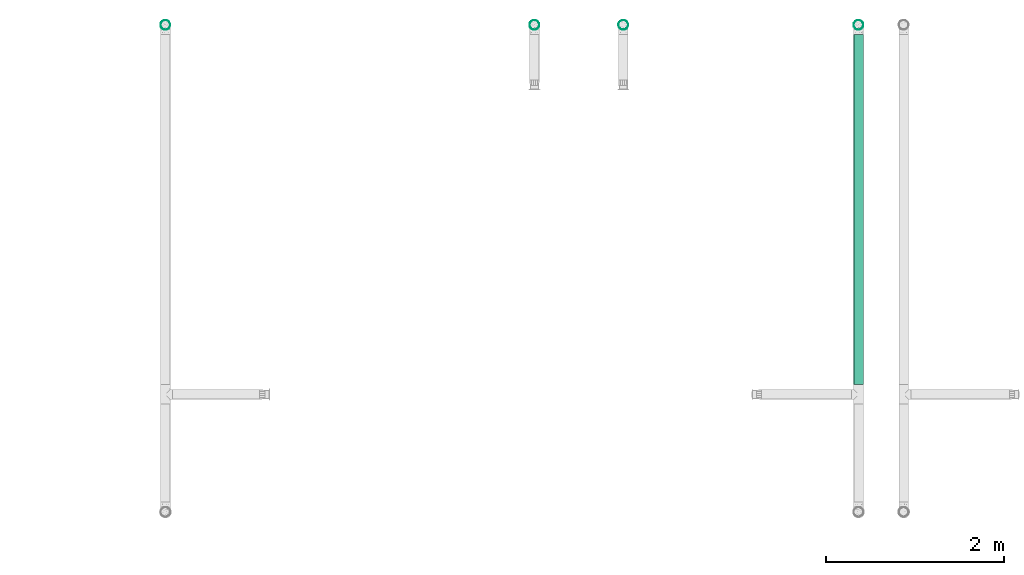
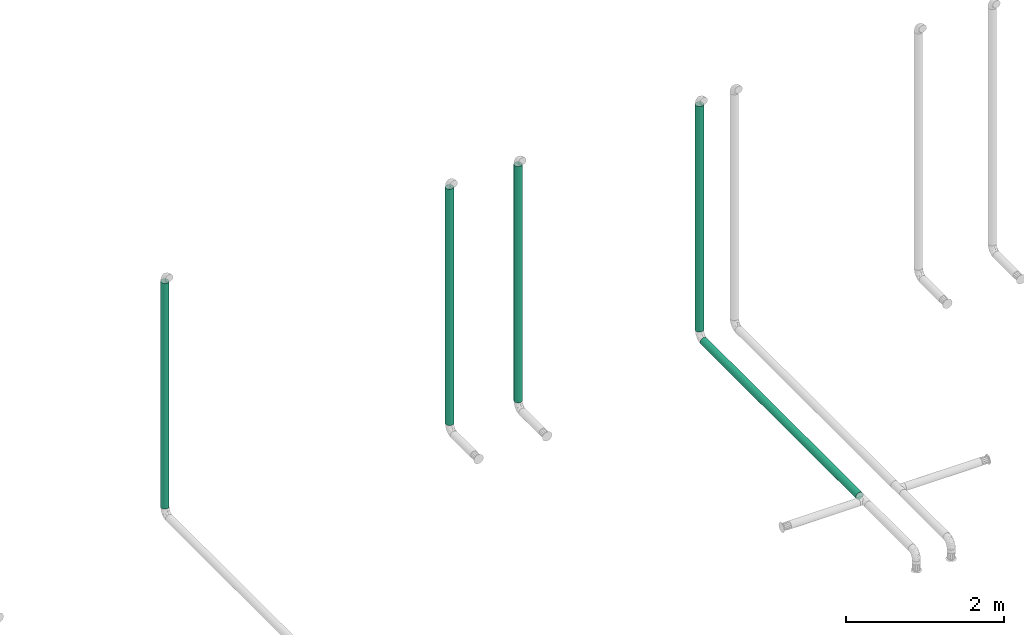
# One storey, part 9 of 115: 5 flow segments.
"""IFC2X3 building model written with IfcOpenShell, lengths in millimetres."""

from ifc_helpers import new_model, entity, si_unit, converted_unit, derived_unit, direction, frame, origin_with_axes, origin_2d_with_axis, place, context, subcontext, project, spatial, hollow_circle, extrude, source, transform, mapped, material, layer, layer_set, layer_usage, type_object, element, save


model = new_model("IFC2X3")

# Units and contexts
model_context = context("Model", 3, precision=1e-05, world=origin_with_axes(), true_north=direction((0.0, 1.0)))
body_context = subcontext(model_context, "Body", "Model", "MODEL_VIEW")
ifc_project = project(units=[si_unit("AREAUNIT", "SQUARE_METRE"), si_unit("VOLUMEUNIT", "CUBIC_METRE", prefix="DECI"), si_unit("TIMEUNIT", "SECOND"), si_unit("THERMODYNAMICTEMPERATUREUNIT", "DEGREE_CELSIUS"), si_unit("PRESSUREUNIT", "PASCAL"), si_unit("MASSUNIT", "GRAM", prefix="KILO"), si_unit("LENGTHUNIT", "METRE", prefix="MILLI"), si_unit("POWERUNIT", "WATT"), si_unit("ELECTRICCURRENTUNIT", "AMPERE"), si_unit("ELECTRICVOLTAGEUNIT", "VOLT"), derived_unit("VOLUMETRICFLOWRATEUNIT", [(si_unit("VOLUMEUNIT", "CUBIC_METRE", prefix="DECI"), 1), (si_unit("TIMEUNIT", "SECOND"), -1)]), derived_unit("LINEARVELOCITYUNIT", [(si_unit("LENGTHUNIT", "METRE"), 1), (si_unit("TIMEUNIT", "SECOND"), -1)]), derived_unit("MASSDENSITYUNIT", [(si_unit("MASSUNIT", "GRAM", prefix="KILO"), 1), (si_unit("VOLUMEUNIT", "CUBIC_METRE"), -1)]), converted_unit("PLANEANGLEUNIT", "DEGREE", entity("IfcRatioMeasure", 0.01745), si_unit("PLANEANGLEUNIT", "RADIAN"), dimensions=[0, 0, 0, 0, 0, 0, 0])], contexts=[model_context])

# Site, building, storey
site_placement = place(None, origin_with_axes())
site = spatial("IfcSite", under=ifc_project, at=site_placement, CompositionType="ELEMENT")
building_placement = place(site_placement, origin_with_axes())
building = spatial("IfcBuilding", under=site, at=building_placement, Name="mc-building", CompositionType="ELEMENT")
storey_placement = place(building_placement, frame((0.0, 0.0, 2950.0), z_axis=(0.0, 0.0, 1.0), x_axis=(1.0, 0.0, 0.0)))
storey = spatial("IfcBuildingStorey", under=building, at=storey_placement, Name="2. Korrus", CompositionType="ELEMENT", Elevation=2950.0)

# Flow segments
ifc_material = material(Name="FZ1")
ifc_layer = layer(ifc_material, 0.0)
ifc_layer_set = layer_set([ifc_layer], Name="FZ1")
ifc_layer_usage = layer_usage(ifc_layer_set, "AXIS1", "POSITIVE", 0.0)
duct_segment_type = type_object("IfcDuctSegmentType", PredefinedType="RIGIDSEGMENT")
shared_shape_1 = source(origin_with_axes(), body_context, "Body", "SweptSolid", [
    extrude(hollow_circle(Radius=55.0, WallThickness=2.0, at=origin_2d_with_axis()), frame((0.0, 0.0, 0.0), z_axis=(1.0, 0.0, 0.0), x_axis=(0.0, 1.0, 0.0)), (0.0, 0.0, 1.0), 3480.0),
])
for number, where, z_axis, x_axis in (
    (1, (26403.5823, 13663.57591, 2575.0), (1.0, 0.0, 0.0), (0.0, 0.0, 1.0)),
    (2, (18604.54349, 13663.57591, 2575.0), (-1.0, 0.0, 0.0), (0.0, 0.0, 1.0)),
):
    element("IfcFlowSegment", number, at=place(storey_placement, frame(where, z_axis=z_axis, x_axis=x_axis)), inside=storey, type_object=duct_segment_type, material=ifc_layer_usage, context=body_context, shape_type="MappedRepresentation", body=[
        mapped(shared_shape_1, transform((0.0, 0.0, 0.0), scale=1.0)),
    ])
shared_shape_2 = source(origin_with_axes(), body_context, "Body", "SweptSolid", [
    extrude(hollow_circle(Radius=55.0, WallThickness=2.0, at=origin_2d_with_axis()), frame((0.0, 0.0, 0.0), z_axis=(1.0, 0.0, 0.0), x_axis=(0.0, 1.0, 0.0)), (0.0, 0.0, 1.0), 3645.0),
])
for number, where, z_axis, x_axis in (
    (3, (23757.14677, 13663.57591, 2410.0), (1.0, 0.0, 0.0), (0.0, 0.0, 1.0)),
    (4, (22757.14677, 13663.57591, 2410.0), (1.0, 0.0, 0.0), (0.0, 0.0, 1.0)),
):
    element("IfcFlowSegment", number, at=place(storey_placement, frame(where, z_axis=z_axis, x_axis=x_axis)), inside=storey, type_object=duct_segment_type, material=ifc_layer_usage, context=body_context, shape_type="MappedRepresentation", body=[
        mapped(shared_shape_2, transform((0.0, 0.0, 0.0), scale=1.0)),
    ])
shared_shape_3 = source(origin_with_axes(), body_context, "Body", "SweptSolid", [
    extrude(hollow_circle(Radius=55.0, WallThickness=2.0, at=origin_2d_with_axis()), frame((0.0, 0.0, 0.0), z_axis=(1.0, 0.0, 0.0), x_axis=(0.0, 1.0, 0.0)), (0.0, 0.0, 1.0), 3938.6),
])
flow_segment_placement = place(storey_placement, frame((26403.5823, 13553.57591, 2465.0), z_axis=(0.0, 0.0, 1.0), x_axis=(0.0, -1.0, 0.0)))
element("IfcFlowSegment", 5, at=flow_segment_placement, inside=storey, type_object=duct_segment_type, material=ifc_layer_usage, context=body_context, shape_type="MappedRepresentation", body=[
    mapped(shared_shape_3, transform((0.0, 0.0, 0.0), scale=1.0)),
])

save(model, "model.ifc")
